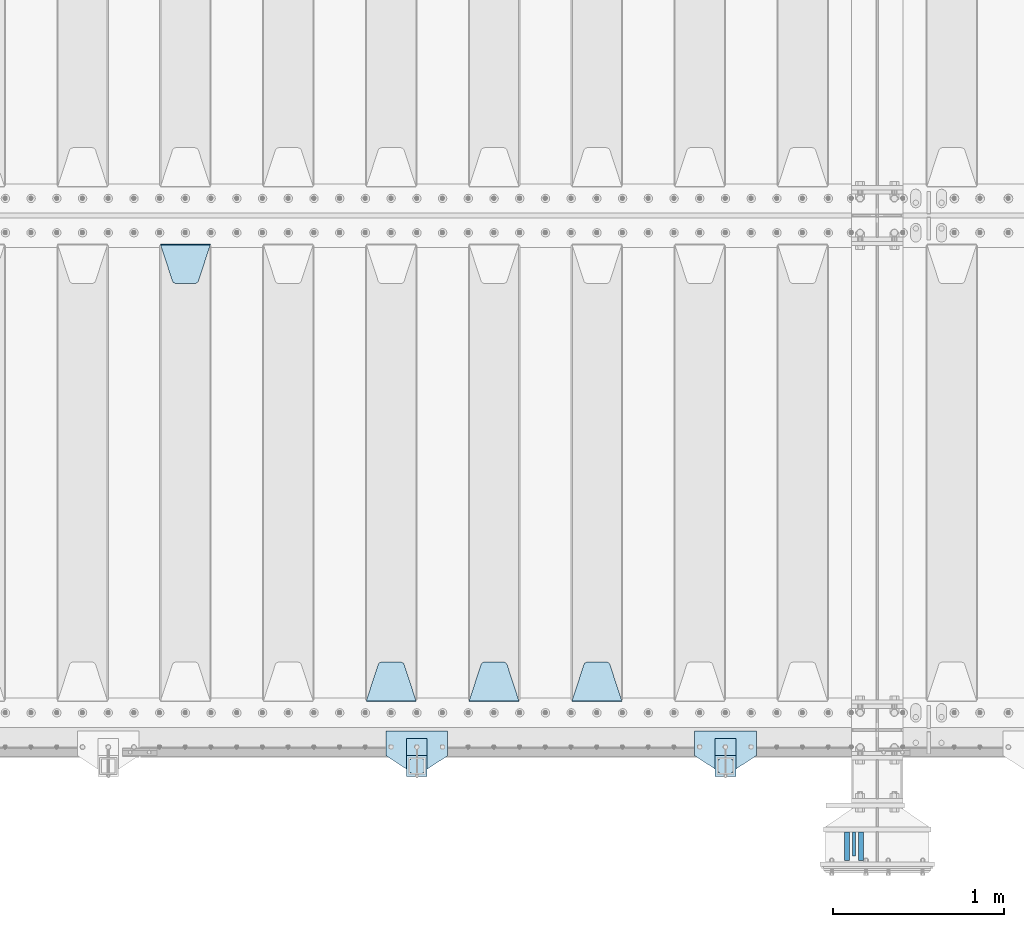
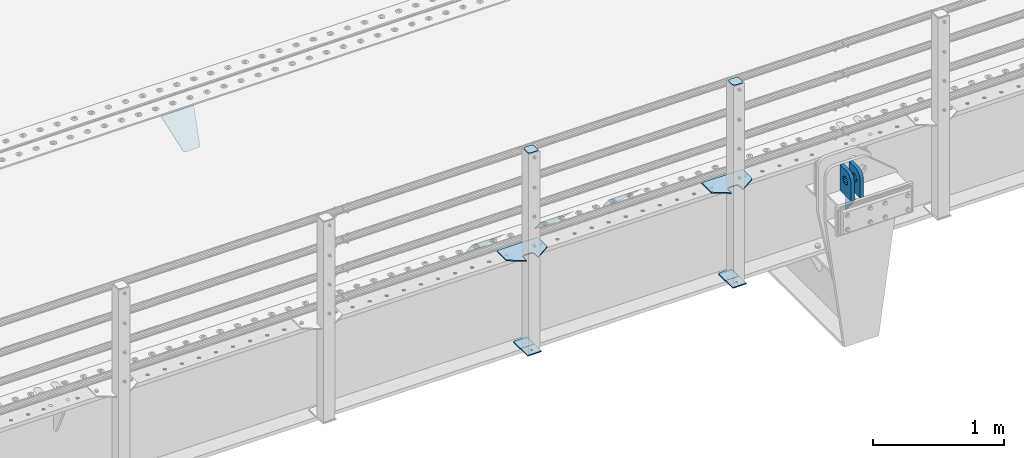
# One storey, part 222 of 270: 15 plates.
"""IFC2X3 building model written with IfcOpenShell, lengths in millimetres."""

from ifc_helpers import new_model, si_unit, frame, origin_with_axes, place, context, subcontext, project, spatial, faceted_brep, material, type_object, element, save


model = new_model("IFC2X3")

# Units and contexts
model_context = context("Model", 3, precision=1e-05, world=origin_with_axes())
body_context = subcontext(model_context, "Body", "Model", "MODEL_VIEW")
ifc_project = project(units=[si_unit("LENGTHUNIT", "METRE", prefix="MILLI"), si_unit("AREAUNIT", "SQUARE_METRE"), si_unit("VOLUMEUNIT", "CUBIC_METRE"), si_unit("MASSUNIT", "GRAM", prefix="KILO"), si_unit("TIMEUNIT", "SECOND"), si_unit("PLANEANGLEUNIT", "RADIAN"), si_unit("SOLIDANGLEUNIT", "STERADIAN"), si_unit("THERMODYNAMICTEMPERATUREUNIT", "DEGREE_CELSIUS"), si_unit("LUMINOUSINTENSITYUNIT", "LUMEN")], contexts=[model_context])

# Site, building, storey
site_placement = place(None, origin_with_axes())
site = spatial("IfcSite", under=ifc_project, at=site_placement, CompositionType="ELEMENT")
building_placement = place(site_placement, origin_with_axes())
building = spatial("IfcBuilding", under=site, at=building_placement, Name="Standard", CompositionType="ELEMENT")
storey_placement = place(building_placement, origin_with_axes())
storey = spatial("IfcBuildingStorey", under=building, at=storey_placement, Name="Undefined", CompositionType="ELEMENT", Elevation=0.0)

# Plates
ifc_material_1 = material(Name="STEEL/S355N")
plate_type_1 = type_object("IfcPlateType", PredefinedType="NOTDEFINED")
plate_1_placement = place(storey_placement, frame((13939.4999999902, -24594.9999999532, -10.0000182055919), z_axis=(0.0, -1.0, 0.0), x_axis=(0.0, 0.0, 1.0)))
element("IfcPlate", 1, at=plate_1_placement, inside=storey, type_object=plate_type_1, material=ifc_material_1, context=body_context, shape_type="Brep", body=[
    faceted_brep([(113.837049096098, 15.0, 53.837049096097), (113.837049096098, -15.0, 53.837049096097), (125.840713002492, -15.0, 45.8164572970818), (125.840713002492, 15.0, 45.8164572970818), (105.816457297082, 15.0, 65.8407130024916), (105.816457297082, -15.0, 65.8407130024916), (103.0, 15.0, 80.0), (103.0, -15.0, 80.0), (105.816457297082, 15.0, 94.1592869975084), (105.816457297082, -15.0, 94.1592869975084), (113.837049096098, 15.0, 106.162950903903), (113.837049096098, -15.0, 106.162950903903), (125.840713002492, 15.0, 114.183542702918), (125.840713002492, -15.0, 114.183542702918), (140.0, 15.0, 117.0), (140.0, -15.0, 117.0), (154.159286997508, 15.0, 114.183542702918), (154.159286997508, -15.0, 114.183542702918), (166.162950903902, 15.0, 106.162950903903), (166.162950903902, -15.0, 106.162950903903), (174.183542702918, 15.0, 94.1592869975084), (174.183542702918, -15.0, 94.1592869975084), (177.0, 15.0, 80.0), (177.0, -15.0, 80.0), (174.183542702918, 15.0, 65.8407130024916), (174.183542702918, -15.0, 65.8407130024916), (166.162950903902, 15.0, 53.837049096097), (166.162950903902, -15.0, 53.837049096097), (154.159286997508, 15.0, 45.8164572970818), (154.159286997508, -15.0, 45.8164572970818), (140.0, 15.0, 43.0), (140.0, -15.0, 43.0), (240.0, -15.0, 0.0), (240.001666876698, -15.0000000000018, 94.9959403776265), (237.616787699976, -15.0000000000018, 113.113322498939), (230.624045898169, -15.0000000000018, 129.996116868071), (219.499985670386, -15.0000000000018, 144.493787979867), (205.002693976271, -15.0000000000018, 155.618342674457), (188.120138118986, -15.0000000000018, 162.611660295071), (170.002837349484, -15.0000000000018, 164.997157401467), (0.0, -15.0, 165.0), (0.0, -15.0, 0.0), (0.0, 15.0, 0.0), (240.0, 15.0, 0.0), (240.001666876698, 14.9999999999982, 94.9959403776265), (237.616787699976, 14.9999999999982, 113.113322498935), (230.624045898169, 14.9999999999982, 129.996116868067), (219.499985670386, 14.9999999999982, 144.493787979864), (205.002693976271, 14.9999999999982, 155.618342674454), (188.120138118986, 14.9999999999982, 162.611660295068), (170.002837349484, 14.9999999999982, 164.997157401463), (0.0, 15.0, 165.0)], [[[0, 1, 2, 3]], [[4, 5, 1, 0]], [[6, 7, 5, 4]], [[8, 9, 7, 6]], [[10, 11, 9, 8]], [[12, 13, 11, 10]], [[14, 15, 13, 12]], [[16, 17, 15, 14]], [[18, 19, 17, 16]], [[20, 21, 19, 18]], [[22, 23, 21, 20]], [[24, 25, 23, 22]], [[26, 27, 25, 24]], [[28, 29, 27, 26]], [[30, 31, 29, 28]], [[3, 2, 31, 30]], [[32, 33, 34, 35, 36, 37, 38, 39, 40, 41], [19, 21, 23, 25, 27, 29, 31, 2, 1, 5, 7, 9, 11, 13, 15, 17]], [[32, 41, 42, 43]], [[33, 32, 43, 44]], [[34, 33, 44, 45]], [[35, 34, 45, 46]], [[36, 35, 46, 47]], [[37, 36, 47, 48]], [[38, 37, 48, 49]], [[39, 38, 49, 50]], [[40, 39, 50, 51]], [[41, 40, 51, 42]], [[50, 49, 48, 47, 46, 45, 44, 43, 42, 51], [10, 8, 6, 4, 0, 3, 30, 28, 26, 24, 22, 20, 18, 16, 14, 12]]]),
])
plate_2_placement = place(storey_placement, frame((13859.4999999919, -24594.9999999532, -10.0000182055919), z_axis=(0.0, -1.0, 0.0), x_axis=(0.0, 0.0, 1.0)))
element("IfcPlate", 2, at=plate_2_placement, inside=storey, type_object=plate_type_1, material=ifc_material_1, context=body_context, shape_type="Brep", body=[
    faceted_brep([(113.837049096098, 15.0, 53.837049096097), (113.837049096098, -15.0, 53.837049096097), (125.840713002492, -15.0, 45.8164572970818), (125.840713002492, 15.0, 45.8164572970818), (105.816457297082, 15.0, 65.8407130024916), (105.816457297082, -15.0, 65.8407130024916), (103.0, 15.0, 80.0), (103.0, -15.0, 80.0), (105.816457297082, 15.0, 94.1592869975084), (105.816457297082, -15.0, 94.1592869975084), (113.837049096098, 15.0, 106.162950903903), (113.837049096098, -15.0, 106.162950903903), (125.840713002492, 15.0, 114.183542702918), (125.840713002492, -15.0, 114.183542702918), (140.0, 15.0, 117.0), (140.0, -15.0, 117.0), (154.159286997508, 15.0, 114.183542702918), (154.159286997508, -15.0, 114.183542702918), (166.162950903902, 15.0, 106.162950903903), (166.162950903902, -15.0, 106.162950903903), (174.183542702918, 15.0, 94.1592869975084), (174.183542702918, -15.0, 94.1592869975084), (177.0, 15.0, 80.0), (177.0, -15.0, 80.0), (174.183542702918, 15.0, 65.8407130024916), (174.183542702918, -15.0, 65.8407130024916), (166.162950903902, 15.0, 53.837049096097), (166.162950903902, -15.0, 53.837049096097), (154.159286997508, 15.0, 45.8164572970818), (154.159286997508, -15.0, 45.8164572970818), (140.0, 15.0, 43.0), (140.0, -15.0, 43.0), (240.0, -15.0, 0.0), (240.0, -15.0, 95.0), (237.614807840235, -15.0, 113.117333157177), (230.621778264911, -15.0, 130.0), (219.497474683058, -15.0, 144.497474683058), (205.0, -15.0, 155.621778264911), (188.117333157176, -15.0, 162.614807840235), (170.0, -15.0, 165.0), (0.0, -15.0, 165.0), (0.0, -15.0, 0.0), (0.0, 15.0, 0.0), (240.0, 15.0, 0.0), (240.0, 15.0, 95.0), (237.614807840235, 15.0, 113.117333157177), (230.621778264911, 15.0, 130.0), (219.497474683058, 15.0, 144.497474683058), (205.0, 15.0, 155.621778264911), (188.117333157176, 15.0, 162.614807840235), (170.0, 15.0, 165.0), (0.0, 15.0, 165.0)], [[[0, 1, 2, 3]], [[4, 5, 1, 0]], [[6, 7, 5, 4]], [[8, 9, 7, 6]], [[10, 11, 9, 8]], [[12, 13, 11, 10]], [[14, 15, 13, 12]], [[16, 17, 15, 14]], [[18, 19, 17, 16]], [[20, 21, 19, 18]], [[22, 23, 21, 20]], [[24, 25, 23, 22]], [[26, 27, 25, 24]], [[28, 29, 27, 26]], [[30, 31, 29, 28]], [[3, 2, 31, 30]], [[32, 33, 34, 35, 36, 37, 38, 39, 40, 41], [19, 21, 23, 25, 27, 29, 31, 2, 1, 5, 7, 9, 11, 13, 15, 17]], [[32, 41, 42, 43]], [[33, 32, 43, 44]], [[34, 33, 44, 45]], [[35, 34, 45, 46]], [[36, 35, 46, 47]], [[37, 36, 47, 48]], [[38, 37, 48, 49]], [[39, 38, 49, 50]], [[40, 39, 50, 51]], [[41, 40, 51, 42]], [[50, 49, 48, 47, 46, 45, 44, 43, 42, 51], [10, 8, 6, 4, 0, 3, 30, 28, 26, 24, 22, 20, 18, 16, 14, 12]]]),
])
plate_type_2 = type_object("IfcPlateType", PredefinedType="NOTDEFINED")
plate_3_placement = place(storey_placement, frame((13899.4999999918, -24734.9999999532, -24.0000182055592), z_axis=(0.0, 0.0, -1.0), x_axis=(0.0, 1.0, 0.0)))
element("IfcPlate", 3, at=plate_3_placement, inside=storey, type_object=plate_type_2, material=ifc_material_1, context=body_context, shape_type="Brep", body=[
    faceted_brep([(0.0, -10.0, 0.0), (140.0, -10.0, 180.0), (140.0, 10.0, 180.0), (0.0, 10.0, 0.0), (140.0, -10.0, -1.81898940354586e-12), (140.0, 10.0, -1.81898940354586e-12)], [[[0, 1, 2, 3]], [[1, 4, 5, 2]], [[4, 0, 3, 5]], [[5, 3, 2]], [[4, 1, 0]]]),
])
ifc_material_2 = material(Name="STEEL/S355J2")
plate_type_3 = type_object("IfcPlateType", PredefinedType="NOTDEFINED")
plate_4_placement = place(storey_placement, frame((13330.0, -24005.0, 5.00000000004911), z_axis=(0.0, -1.0, 0.0), x_axis=(-1.0, 0.0, 0.0)))
element("IfcPlate", 4, at=plate_4_placement, inside=storey, type_object=plate_type_3, material=ifc_material_2, context=body_context, shape_type="Brep", body=[
    faceted_brep([(0.0, -5.0, 0.0), (2.31396552408114e-06, -5.0, 145.0), (2.31396552408114e-06, 5.0, 145.0), (0.0, 5.0, 0.0), (130.0, -5.0, 230.0), (130.0, 5.0, 230.0), (130.0, -5.0, 180.0), (130.0, 5.0, 180.0), (130.48036798992, -5.0, 175.122741949597), (130.48036798992, 5.0, 175.122741949597), (131.903011687216, -5.0, 170.432914190873), (131.903011687216, 5.0, 170.432914190873), (134.213259692435, -5.0, 166.11074417451), (134.213259692435, 5.0, 166.11074417451), (137.322330470335, -5.0, 162.322330470337), (137.322330470335, 5.0, 162.322330470337), (141.110744174512, -5.0, 159.213259692437), (141.110744174512, 5.0, 159.213259692437), (145.432914190871, -5.0, 156.903011687218), (145.432914190871, 5.0, 156.903011687218), (150.122741949595, -5.0, 155.48036798992), (150.122741949595, 5.0, 155.48036798992), (155.0, -5.0, 155.0), (155.0, 5.0, 155.0), (205.0, -5.0, 155.0), (205.0, 5.0, 155.0), (209.877258050405, -5.0, 155.48036798992), (209.877258050405, 5.0, 155.48036798992), (214.567085809129, -5.0, 156.903011687218), (214.567085809129, 5.0, 156.903011687218), (218.889255825488, -5.0, 159.213259692437), (218.889255825488, 5.0, 159.213259692437), (222.677669529665, -5.0, 162.322330470337), (222.677669529665, 5.0, 162.322330470337), (225.786740307565, -5.0, 166.11074417451), (225.786740307565, 5.0, 166.11074417451), (228.096988312784, -5.0, 170.432914190873), (228.096988312784, 5.0, 170.432914190873), (229.51963201008, -5.0, 175.122741949597), (229.51963201008, 5.0, 175.122741949597), (230.0, -5.0, 180.0), (230.0, 5.0, 180.0), (230.0, -5.0, 230.0), (230.0, 5.0, 230.0), (360.0, -5.0, 145.0), (360.0, 5.0, 145.0), (360.0, -5.0, -7.27595761418343e-12), (360.0, 5.0, -7.27595761418343e-12)], [[[0, 1, 2, 3]], [[1, 4, 5, 2]], [[4, 6, 7, 5]], [[6, 8, 9, 7]], [[8, 10, 11, 9]], [[10, 12, 13, 11]], [[12, 14, 15, 13]], [[14, 16, 17, 15]], [[16, 18, 19, 17]], [[18, 20, 21, 19]], [[20, 22, 23, 21]], [[22, 24, 25, 23]], [[24, 26, 27, 25]], [[26, 28, 29, 27]], [[28, 30, 31, 29]], [[30, 32, 33, 31]], [[32, 34, 35, 33]], [[34, 36, 37, 35]], [[36, 38, 39, 37]], [[38, 40, 41, 39]], [[40, 42, 43, 41]], [[42, 44, 45, 43]], [[44, 46, 47, 45]], [[46, 0, 3, 47]], [[5, 7, 9, 11, 13, 15, 17, 19, 21, 23, 25, 27, 29, 31, 33, 35, 37, 39, 41, 43, 45, 47, 3, 2]], [[46, 44, 42, 40, 38, 36, 34, 32, 30, 28, 26, 24, 22, 20, 18, 16, 14, 12, 10, 8, 6, 4, 1, 0]]]),
])
plate_5_placement = place(storey_placement, frame((11530.0, -24005.0, 5.00000000004911), z_axis=(0.0, -1.0, 0.0), x_axis=(-1.0, 0.0, 0.0)))
element("IfcPlate", 5, at=plate_5_placement, inside=storey, type_object=plate_type_3, material=ifc_material_2, context=body_context, shape_type="Brep", body=[
    faceted_brep([(0.0, -5.0, 0.0), (2.31396552408114e-06, -5.0, 145.0), (2.31396552408114e-06, 5.0, 145.0), (0.0, 5.0, 0.0), (130.0, -5.0, 230.0), (130.0, 5.0, 230.0), (130.0, -5.0, 180.0), (130.0, 5.0, 180.0), (130.48036798992, -5.0, 175.122741949597), (130.48036798992, 5.0, 175.122741949597), (131.903011687216, -5.0, 170.432914190873), (131.903011687216, 5.0, 170.432914190873), (134.213259692435, -5.0, 166.11074417451), (134.213259692435, 5.0, 166.11074417451), (137.322330470335, -5.0, 162.322330470337), (137.322330470335, 5.0, 162.322330470337), (141.110744174512, -5.0, 159.213259692437), (141.110744174512, 5.0, 159.213259692437), (145.432914190871, -5.0, 156.903011687218), (145.432914190871, 5.0, 156.903011687218), (150.122741949595, -5.0, 155.48036798992), (150.122741949595, 5.0, 155.48036798992), (155.0, -5.0, 155.0), (155.0, 5.0, 155.0), (205.0, -5.0, 155.0), (205.0, 5.0, 155.0), (209.877258050405, -5.0, 155.48036798992), (209.877258050405, 5.0, 155.48036798992), (214.567085809129, -5.0, 156.903011687218), (214.567085809129, 5.0, 156.903011687218), (218.889255825488, -5.0, 159.213259692437), (218.889255825488, 5.0, 159.213259692437), (222.677669529665, -5.0, 162.322330470337), (222.677669529665, 5.0, 162.322330470337), (225.786740307565, -5.0, 166.11074417451), (225.786740307565, 5.0, 166.11074417451), (228.096988312784, -5.0, 170.432914190873), (228.096988312784, 5.0, 170.432914190873), (229.51963201008, -5.0, 175.122741949597), (229.51963201008, 5.0, 175.122741949597), (230.0, -5.0, 180.0), (230.0, 5.0, 180.0), (230.0, -5.0, 230.0), (230.0, 5.0, 230.0), (360.0, -5.0, 145.0), (360.0, 5.0, 145.0), (360.0, -5.0, -7.27595761418343e-12), (360.0, 5.0, -7.27595761418343e-12)], [[[0, 1, 2, 3]], [[1, 4, 5, 2]], [[4, 6, 7, 5]], [[6, 8, 9, 7]], [[8, 10, 11, 9]], [[10, 12, 13, 11]], [[12, 14, 15, 13]], [[14, 16, 17, 15]], [[16, 18, 19, 17]], [[18, 20, 21, 19]], [[20, 22, 23, 21]], [[22, 24, 25, 23]], [[24, 26, 27, 25]], [[26, 28, 29, 27]], [[28, 30, 31, 29]], [[30, 32, 33, 31]], [[32, 34, 35, 33]], [[34, 36, 37, 35]], [[36, 38, 39, 37]], [[38, 40, 41, 39]], [[40, 42, 43, 41]], [[42, 44, 45, 43]], [[44, 46, 47, 45]], [[46, 0, 3, 47]], [[5, 7, 9, 11, 13, 15, 17, 19, 21, 23, 25, 27, 29, 31, 33, 35, 37, 39, 41, 43, 45, 47, 3, 2]], [[46, 44, 42, 40, 38, 36, 34, 32, 30, 28, 26, 24, 22, 20, 18, 16, 14, 12, 10, 8, 6, 4, 1, 0]]]),
])
plate_type_4 = type_object("IfcPlateType", PredefinedType="NOTDEFINED")
for number, where, z_axis, x_axis in (
    (6, (13209.9999999999, -24050.0000000002, -850.000000000002), (0.0, -1.0, 0.0), (-1.0, 0.0, 0.0)),
    (7, (11409.9999999999, -24050.0000000002, -850.000000000002), (0.0, -1.0, 0.0), (-1.0, 0.0, 0.0)),
):
    element("IfcPlate", number, at=place(storey_placement, frame(where, z_axis=z_axis, x_axis=x_axis)), inside=storey, type_object=plate_type_4, material=ifc_material_2, context=body_context, shape_type="Brep", body=[
        faceted_brep([(53.6360389691836, -5.0, 176.363961030471), (53.6360389691836, 5.0, 176.363961030471), (59.9999999998618, 5.0, 178.999999999793), (59.9999999998618, -5.0, 178.999999999793), (66.3639610305399, 5.0, 176.363961030471), (66.3639610305399, -5.0, 176.363961030471), (68.9999999998618, 5.0, 169.999999999793), (68.9999999998618, -5.0, 169.999999999793), (66.3639610305399, 5.0, 163.636038969114), (66.3639610305399, -5.0, 163.636038969114), (59.9999999998618, 5.0, 160.999999999793), (59.9999999998618, -5.0, 160.999999999793), (53.6360389691836, 5.0, 163.636038969114), (53.6360389691836, -5.0, 163.636038969114), (50.9999999998618, 5.0, 169.999999999793), (50.9999999998618, -5.0, 169.999999999793), (120.0, -5.0, 0.0), (120.0, -5.0, 220.0), (0.0, -5.0, 220.0), (0.0, -5.0, 0.0), (0.0, 5.0, 0.0), (120.0, 5.0, 0.0), (120.0, 5.0, 220.0), (0.0, 5.0, 220.0)], [[[0, 1, 2, 3]], [[3, 2, 4, 5]], [[5, 4, 6, 7]], [[7, 6, 8, 9]], [[9, 8, 10, 11]], [[11, 10, 12, 13]], [[13, 12, 14, 15]], [[15, 14, 1, 0]], [[16, 17, 18, 19], [11, 13, 15, 0, 3, 5, 7, 9]], [[16, 19, 20, 21]], [[17, 16, 21, 22]], [[18, 17, 22, 23]], [[19, 18, 23, 20]], [[22, 21, 20, 23], [2, 1, 14, 12, 10, 8, 6, 4]]]),
    ])
plate_type_5 = type_object("IfcPlateType", PredefinedType="NOTDEFINED")
plate_6_placement = place(storey_placement, frame((13105.9999999999, -24166.0000000002, 1012.50000000001), z_axis=(0.0, -1.0, 0.0), x_axis=(1.0, 0.0, 0.0)))
element("IfcPlate", 8, at=plate_6_placement, inside=storey, type_object=plate_type_5, material=ifc_material_2, context=body_context, shape_type="Brep", body=[
    faceted_brep([(0.0, -2.5, 19.0), (0.0, -2.5, 69.0), (0.0, 2.5, 69.0), (0.0, 2.5, 19.0), (0.476369668544066, -2.5, 73.2278977451697), (0.476369668544066, 2.5, 73.2278977451697), (1.88159150985302, -2.5, 77.2437910432327), (1.88159150985302, 2.5, 77.2437910432327), (4.14520183310742, -2.5, 80.8463062353167), (4.14520183310742, 2.5, 80.8463062353167), (7.15369376468516, -2.5, 83.8547981668926), (7.15369376468516, 2.5, 83.8547981668926), (10.7562089567655, -2.5, 86.1184084901452), (10.7562089567655, 2.5, 86.1184084901452), (14.7721022548285, -2.5, 87.5236303314541), (14.7721022548285, 2.5, 87.5236303314541), (19.0, -2.5, 88.0), (19.0, 2.5, 88.0), (69.0, -2.5, 88.0), (69.0, 2.5, 88.0), (73.2278977451715, -2.5, 87.5236303314541), (73.2278977451715, 2.5, 87.5236303314541), (77.2437910432345, -2.5, 86.1184084901452), (77.2437910432345, 2.5, 86.1184084901452), (80.8463062353148, -2.5, 83.8547981668926), (80.8463062353148, 2.5, 83.8547981668926), (83.8547981668926, -2.5, 80.8463062353167), (83.8547981668926, 2.5, 80.8463062353167), (86.118408490147, -2.5, 77.2437910432345), (86.118408490147, 2.5, 77.2437910432345), (87.5236303314559, -2.5, 73.2278977451697), (87.5236303314559, 2.5, 73.2278977451697), (88.0, -2.5, 69.0), (88.0, 2.5, 69.0), (88.0, -2.5, 19.0), (88.0, 2.5, 19.0), (87.5236303314559, -2.5, 14.7721022548303), (87.5236303314559, 2.5, 14.7721022548303), (86.118408490147, -2.5, 10.7562089567673), (86.118408490147, 2.5, 10.7562089567673), (83.8547981668926, -2.5, 7.15369376468334), (83.8547981668926, 2.5, 7.15369376468334), (80.8463062353148, -2.5, 4.14520183310742), (80.8463062353148, 2.5, 4.14520183310742), (77.2437910432345, -2.5, 1.88159150985484), (77.2437910432345, 2.5, 1.88159150985484), (73.2278977451715, -2.5, 0.476369668545885), (73.2278977451715, 2.5, 0.476369668545885), (69.0, -2.5, 0.0), (69.0, 2.5, 0.0), (19.0, -2.5, 0.0), (19.0, 2.5, 0.0), (14.7721022548285, -2.5, 0.476369668545885), (14.7721022548285, 2.5, 0.476369668545885), (10.7562089567655, -2.5, 1.88159150985484), (10.7562089567655, 2.5, 1.88159150985484), (7.15369376468516, -2.5, 4.14520183310742), (7.15369376468516, 2.5, 4.14520183310742), (4.14520183310742, -2.5, 7.15369376468334), (4.14520183310742, 2.5, 7.15369376468334), (1.88159150985302, -2.5, 10.7562089567673), (1.88159150985302, 2.5, 10.7562089567673), (0.476369668544066, -2.5, 14.7721022548303), (0.476369668544066, 2.5, 14.7721022548303)], [[[0, 1, 2, 3]], [[1, 4, 5, 2]], [[4, 6, 7, 5]], [[6, 8, 9, 7]], [[8, 10, 11, 9]], [[10, 12, 13, 11]], [[12, 14, 15, 13]], [[14, 16, 17, 15]], [[16, 18, 19, 17]], [[18, 20, 21, 19]], [[20, 22, 23, 21]], [[22, 24, 25, 23]], [[24, 26, 27, 25]], [[26, 28, 29, 27]], [[28, 30, 31, 29]], [[30, 32, 33, 31]], [[32, 34, 35, 33]], [[34, 36, 37, 35]], [[36, 38, 39, 37]], [[38, 40, 41, 39]], [[40, 42, 43, 41]], [[42, 44, 45, 43]], [[44, 46, 47, 45]], [[46, 48, 49, 47]], [[48, 50, 51, 49]], [[50, 52, 53, 51]], [[52, 54, 55, 53]], [[54, 56, 57, 55]], [[56, 58, 59, 57]], [[58, 60, 61, 59]], [[60, 62, 63, 61]], [[62, 0, 3, 63]], [[5, 7, 9, 11, 13, 15, 17, 19, 21, 23, 25, 27, 29, 31, 33, 35, 37, 39, 41, 43, 45, 47, 49, 51, 53, 55, 57, 59, 61, 63, 3, 2]], [[62, 60, 58, 56, 54, 52, 50, 48, 46, 44, 42, 40, 38, 36, 34, 32, 30, 28, 26, 24, 22, 20, 18, 16, 14, 12, 10, 8, 6, 4, 1, 0]]]),
])
plate_7_placement = place(storey_placement, frame((11305.9999999999, -24166.0000000002, 1012.50000000001), z_axis=(0.0, -1.0, 0.0), x_axis=(1.0, 0.0, 0.0)))
element("IfcPlate", 9, at=plate_7_placement, inside=storey, type_object=plate_type_5, material=ifc_material_2, context=body_context, shape_type="Brep", body=[
    faceted_brep([(0.0, -2.5, 19.0), (0.0, -2.5, 69.0), (0.0, 2.5, 69.0), (0.0, 2.5, 19.0), (0.476369668544066, -2.5, 73.2278977451697), (0.476369668544066, 2.5, 73.2278977451697), (1.88159150985302, -2.5, 77.2437910432327), (1.88159150985302, 2.5, 77.2437910432327), (4.14520183310742, -2.5, 80.8463062353167), (4.14520183310742, 2.5, 80.8463062353167), (7.15369376468516, -2.5, 83.8547981668926), (7.15369376468516, 2.5, 83.8547981668926), (10.7562089567655, -2.5, 86.1184084901452), (10.7562089567655, 2.5, 86.1184084901452), (14.7721022548285, -2.5, 87.5236303314541), (14.7721022548285, 2.5, 87.5236303314541), (19.0, -2.5, 88.0), (19.0, 2.5, 88.0), (69.0, -2.5, 88.0), (69.0, 2.5, 88.0), (73.2278977451715, -2.5, 87.5236303314541), (73.2278977451715, 2.5, 87.5236303314541), (77.2437910432345, -2.5, 86.1184084901452), (77.2437910432345, 2.5, 86.1184084901452), (80.8463062353148, -2.5, 83.8547981668926), (80.8463062353148, 2.5, 83.8547981668926), (83.8547981668926, -2.5, 80.8463062353167), (83.8547981668926, 2.5, 80.8463062353167), (86.118408490147, -2.5, 77.2437910432345), (86.118408490147, 2.5, 77.2437910432345), (87.5236303314559, -2.5, 73.2278977451697), (87.5236303314559, 2.5, 73.2278977451697), (88.0, -2.5, 69.0), (88.0, 2.5, 69.0), (88.0, -2.5, 19.0), (88.0, 2.5, 19.0), (87.5236303314559, -2.5, 14.7721022548303), (87.5236303314559, 2.5, 14.7721022548303), (86.118408490147, -2.5, 10.7562089567673), (86.118408490147, 2.5, 10.7562089567673), (83.8547981668926, -2.5, 7.15369376468334), (83.8547981668926, 2.5, 7.15369376468334), (80.8463062353148, -2.5, 4.14520183310742), (80.8463062353148, 2.5, 4.14520183310742), (77.2437910432345, -2.5, 1.88159150985484), (77.2437910432345, 2.5, 1.88159150985484), (73.2278977451715, -2.5, 0.476369668545885), (73.2278977451715, 2.5, 0.476369668545885), (69.0, -2.5, 0.0), (69.0, 2.5, 0.0), (19.0, -2.5, 0.0), (19.0, 2.5, 0.0), (14.7721022548285, -2.5, 0.476369668545885), (14.7721022548285, 2.5, 0.476369668545885), (10.7562089567655, -2.5, 1.88159150985484), (10.7562089567655, 2.5, 1.88159150985484), (7.15369376468516, -2.5, 4.14520183310742), (7.15369376468516, 2.5, 4.14520183310742), (4.14520183310742, -2.5, 7.15369376468334), (4.14520183310742, 2.5, 7.15369376468334), (1.88159150985302, -2.5, 10.7562089567673), (1.88159150985302, 2.5, 10.7562089567673), (0.476369668544066, -2.5, 14.7721022548303), (0.476369668544066, 2.5, 14.7721022548303)], [[[0, 1, 2, 3]], [[1, 4, 5, 2]], [[4, 6, 7, 5]], [[6, 8, 9, 7]], [[8, 10, 11, 9]], [[10, 12, 13, 11]], [[12, 14, 15, 13]], [[14, 16, 17, 15]], [[16, 18, 19, 17]], [[18, 20, 21, 19]], [[20, 22, 23, 21]], [[22, 24, 25, 23]], [[24, 26, 27, 25]], [[26, 28, 29, 27]], [[28, 30, 31, 29]], [[30, 32, 33, 31]], [[32, 34, 35, 33]], [[34, 36, 37, 35]], [[36, 38, 39, 37]], [[38, 40, 41, 39]], [[40, 42, 43, 41]], [[42, 44, 45, 43]], [[44, 46, 47, 45]], [[46, 48, 49, 47]], [[48, 50, 51, 49]], [[50, 52, 53, 51]], [[52, 54, 55, 53]], [[54, 56, 57, 55]], [[56, 58, 59, 57]], [[58, 60, 61, 59]], [[60, 62, 63, 61]], [[62, 0, 3, 63]], [[5, 7, 9, 11, 13, 15, 17, 19, 21, 23, 25, 27, 29, 31, 33, 35, 37, 39, 41, 43, 45, 47, 49, 51, 53, 55, 57, 59, 61, 63, 3, 2]], [[62, 60, 58, 56, 54, 52, 50, 48, 46, 44, 42, 40, 38, 36, 34, 32, 30, 28, 26, 24, 22, 20, 18, 16, 14, 12, 10, 8, 6, 4, 1, 0]]]),
])
plate_type_6 = type_object("IfcPlateType", PredefinedType="NOTDEFINED")
for number, where, z_axis, x_axis in (
    (10, (13209.9999999999, -24050.0000000002, -857.500000000002), (0.0, -1.0, 0.0), (-1.0, 0.0, 0.0)),
    (11, (11409.9999999999, -24050.0000000002, -857.500000000002), (0.0, -1.0, 0.0), (-1.0, 0.0, 0.0)),
):
    element("IfcPlate", number, at=place(storey_placement, frame(where, z_axis=z_axis, x_axis=x_axis)), inside=storey, type_object=plate_type_6, material=ifc_material_2, context=body_context, shape_type="Brep", body=[
        faceted_brep([(0.0, -2.5, 0.0), (0.0, -2.5, 100.0), (0.0, 2.5, 100.0), (0.0, 2.5, 0.0), (120.0, -2.5, 100.0), (120.0, 2.5, 100.0), (120.0, -2.5, 0.0), (120.0, 2.5, 0.0)], [[[0, 1, 2, 3]], [[1, 4, 5, 2]], [[4, 6, 7, 5]], [[6, 0, 3, 7]], [[5, 7, 3, 2]], [[6, 4, 1, 0]]]),
    ])
plate_type_7 = type_object("IfcPlateType", PredefinedType="NOTDEFINED")
plate_8_placement = place(storey_placement, frame((12545.0, -23831.767766953, -1.76776695296758), z_axis=(0.0, 0.707106781186547, -0.707106781186548), x_axis=(-1.0, 0.0, 0.0)))
element("IfcPlate", 12, at=plate_8_placement, inside=storey, type_object=plate_type_7, material=ifc_material_1, context=body_context, shape_type="Brep", body=[
    faceted_brep([(0.0, -2.5, 0.0), (69.345504679477, -2.5, 300.171731424831), (69.345504679477, 2.5, 300.171731424831), (0.0, 2.5, 0.0), (70.9274061199576, -2.5, 304.8974424154), (70.9274061199576, 2.5, 304.8974424154), (73.3818627772307, -2.49999999999818, 309.234538108527), (73.3818627772307, 2.50000000000182, 309.234538108527), (76.6187032999551, -2.5, 313.023683126103), (76.6187032999551, 2.5, 313.023683126103), (80.5190132704993, -2.5, 316.125672595372), (80.5190132704993, 2.50000000000182, 316.125672595372), (84.9395038596849, -2.49999999999818, 318.426546230476), (84.9395038596849, 2.5, 318.426546230476), (89.7177759439219, -2.49999999999818, 319.841774983275), (89.7177759439219, 2.50000000000182, 319.841774983275), (94.678286292652, -2.5, 320.319366455078), (94.678286292652, 2.5, 320.319366455078), (195.321713707348, -2.5, 320.319366455078), (195.321713707348, 2.5, 320.319366455078), (200.282224056078, -2.49999999999818, 319.841774983275), (200.282224056078, 2.50000000000182, 319.841774983275), (205.060496140315, -2.5, 318.426546230476), (205.060496140315, 2.5, 318.426546230476), (209.480986729501, -2.5, 316.12567259537), (209.480986729501, 2.50000000000182, 316.12567259537), (213.381296700045, -2.5, 313.023683126103), (213.381296700045, 2.5, 313.023683126103), (216.618137222769, -2.49999999999818, 309.234538108525), (216.618137222769, 2.50000000000182, 309.234538108527), (219.072593880042, -2.49999999999818, 304.897442415398), (219.072593880042, 2.50000000000182, 304.897442415397), (220.654495320523, -2.5, 300.171731424831), (220.654495320523, 2.5, 300.171731424831), (290.0, -2.49999999999818, 0.0), (290.0, 2.5, 0.0)], [[[0, 1, 2, 3]], [[1, 4, 5, 2]], [[4, 6, 7, 5]], [[6, 8, 9, 7]], [[8, 10, 11, 9]], [[10, 12, 13, 11]], [[12, 14, 15, 13]], [[14, 16, 17, 15]], [[16, 18, 19, 17]], [[18, 20, 21, 19]], [[20, 22, 23, 21]], [[22, 24, 25, 23]], [[24, 26, 27, 25]], [[26, 28, 29, 27]], [[28, 30, 31, 29]], [[30, 32, 33, 31]], [[32, 34, 35, 33]], [[34, 0, 3, 35]], [[5, 7, 9, 11, 13, 15, 17, 19, 21, 23, 25, 27, 29, 31, 33, 35, 3, 2]], [[34, 32, 30, 28, 26, 24, 22, 20, 18, 16, 14, 12, 10, 8, 6, 4, 1, 0]]]),
])
plate_9_placement = place(storey_placement, frame((11945.0, -23831.767766953, -1.76776695296758), z_axis=(0.0, 0.707106781186547, -0.707106781186548), x_axis=(-1.0, 0.0, 0.0)))
element("IfcPlate", 13, at=plate_9_placement, inside=storey, type_object=plate_type_7, material=ifc_material_1, context=body_context, shape_type="Brep", body=[
    faceted_brep([(0.0, -2.5, 0.0), (69.345504679477, -2.5, 300.171731424831), (69.345504679477, 2.5, 300.171731424831), (0.0, 2.5, 0.0), (70.9274061199576, -2.5, 304.8974424154), (70.9274061199576, 2.5, 304.8974424154), (73.3818627772307, -2.49999999999818, 309.234538108527), (73.3818627772307, 2.50000000000182, 309.234538108527), (76.6187032999551, -2.5, 313.023683126103), (76.6187032999551, 2.5, 313.023683126103), (80.5190132704993, -2.5, 316.125672595372), (80.5190132704993, 2.50000000000182, 316.125672595372), (84.9395038596849, -2.49999999999818, 318.426546230476), (84.9395038596849, 2.5, 318.426546230476), (89.7177759439219, -2.49999999999818, 319.841774983275), (89.7177759439219, 2.50000000000182, 319.841774983275), (94.678286292652, -2.5, 320.319366455078), (94.678286292652, 2.5, 320.319366455078), (195.321713707348, -2.5, 320.319366455078), (195.321713707348, 2.5, 320.319366455078), (200.282224056078, -2.49999999999818, 319.841774983275), (200.282224056078, 2.50000000000182, 319.841774983275), (205.060496140315, -2.5, 318.426546230476), (205.060496140315, 2.5, 318.426546230476), (209.480986729501, -2.5, 316.12567259537), (209.480986729501, 2.50000000000182, 316.12567259537), (213.381296700045, -2.5, 313.023683126103), (213.381296700045, 2.5, 313.023683126103), (216.618137222769, -2.49999999999818, 309.234538108525), (216.618137222769, 2.50000000000182, 309.234538108527), (219.072593880042, -2.49999999999818, 304.897442415398), (219.072593880042, 2.50000000000182, 304.897442415397), (220.654495320523, -2.5, 300.171731424831), (220.654495320523, 2.5, 300.171731424831), (290.0, -2.49999999999818, 0.0), (290.0, 2.5, 0.0)], [[[0, 1, 2, 3]], [[1, 4, 5, 2]], [[4, 6, 7, 5]], [[6, 8, 9, 7]], [[8, 10, 11, 9]], [[10, 12, 13, 11]], [[12, 14, 15, 13]], [[14, 16, 17, 15]], [[16, 18, 19, 17]], [[18, 20, 21, 19]], [[20, 22, 23, 21]], [[22, 24, 25, 23]], [[24, 26, 27, 25]], [[26, 28, 29, 27]], [[28, 30, 31, 29]], [[30, 32, 33, 31]], [[32, 34, 35, 33]], [[34, 0, 3, 35]], [[5, 7, 9, 11, 13, 15, 17, 19, 21, 23, 25, 27, 29, 31, 33, 35, 3, 2]], [[34, 32, 30, 28, 26, 24, 22, 20, 18, 16, 14, 12, 10, 8, 6, 4, 1, 0]]]),
])
plate_10_placement = place(storey_placement, frame((11345.0, -23831.767766953, -1.76776695296758), z_axis=(0.0, 0.707106781186547, -0.707106781186548), x_axis=(-1.0, 0.0, 0.0)))
element("IfcPlate", 14, at=plate_10_placement, inside=storey, type_object=plate_type_7, material=ifc_material_1, context=body_context, shape_type="Brep", body=[
    faceted_brep([(0.0, -2.5, 0.0), (69.345504679477, -2.5, 300.171731424831), (69.345504679477, 2.5, 300.171731424831), (0.0, 2.5, 0.0), (70.9274061199576, -2.5, 304.8974424154), (70.9274061199576, 2.5, 304.8974424154), (73.3818627772307, -2.49999999999818, 309.234538108527), (73.3818627772307, 2.50000000000182, 309.234538108527), (76.6187032999551, -2.5, 313.023683126103), (76.6187032999551, 2.5, 313.023683126103), (80.5190132704993, -2.5, 316.125672595372), (80.5190132704993, 2.50000000000182, 316.125672595372), (84.9395038596849, -2.49999999999818, 318.426546230476), (84.9395038596849, 2.5, 318.426546230476), (89.7177759439219, -2.49999999999818, 319.841774983275), (89.7177759439219, 2.50000000000182, 319.841774983275), (94.678286292652, -2.5, 320.319366455078), (94.678286292652, 2.5, 320.319366455078), (195.321713707348, -2.5, 320.319366455078), (195.321713707348, 2.5, 320.319366455078), (200.282224056078, -2.49999999999818, 319.841774983275), (200.282224056078, 2.50000000000182, 319.841774983275), (205.060496140315, -2.5, 318.426546230476), (205.060496140315, 2.5, 318.426546230476), (209.480986729501, -2.5, 316.12567259537), (209.480986729501, 2.50000000000182, 316.12567259537), (213.381296700045, -2.5, 313.023683126103), (213.381296700045, 2.5, 313.023683126103), (216.618137222769, -2.49999999999818, 309.234538108525), (216.618137222769, 2.50000000000182, 309.234538108527), (219.072593880042, -2.49999999999818, 304.897442415398), (219.072593880042, 2.50000000000182, 304.897442415397), (220.654495320523, -2.5, 300.171731424831), (220.654495320523, 2.5, 300.171731424831), (290.0, -2.49999999999818, 0.0), (290.0, 2.5, 0.0)], [[[0, 1, 2, 3]], [[1, 4, 5, 2]], [[4, 6, 7, 5]], [[6, 8, 9, 7]], [[8, 10, 11, 9]], [[10, 12, 13, 11]], [[12, 14, 15, 13]], [[14, 16, 17, 15]], [[16, 18, 19, 17]], [[18, 20, 21, 19]], [[20, 22, 23, 21]], [[22, 24, 25, 23]], [[24, 26, 27, 25]], [[26, 28, 29, 27]], [[28, 30, 31, 29]], [[30, 32, 33, 31]], [[32, 34, 35, 33]], [[34, 0, 3, 35]], [[5, 7, 9, 11, 13, 15, 17, 19, 21, 23, 25, 27, 29, 31, 33, 35, 3, 2]], [[34, 32, 30, 28, 26, 24, 22, 20, 18, 16, 14, 12, 10, 8, 6, 4, 1, 0]]]),
])
plate_11_placement = place(storey_placement, frame((9855.0, -21168.232233044, -1.76776695296576), z_axis=(0.0, -0.707106781186548, -0.707106781186547), x_axis=(1.0, 0.0, 0.0)))
element("IfcPlate", 15, at=plate_11_placement, inside=storey, type_object=plate_type_7, material=ifc_material_1, context=body_context, shape_type="Brep", body=[
    faceted_brep([(0.0, -2.5, 0.0), (69.345504679477, -2.5, 300.171731424831), (69.345504679477, 2.5, 300.171731424831), (0.0, 2.5, 0.0), (70.9274061199576, -2.5, 304.8974424154), (70.9274061199576, 2.5, 304.8974424154), (73.3818627772307, -2.49999999999818, 309.234538108527), (73.3818627772307, 2.50000000000182, 309.234538108527), (76.6187032999551, -2.5, 313.023683126103), (76.6187032999551, 2.5, 313.023683126103), (80.5190132704993, -2.5, 316.125672595372), (80.5190132704993, 2.50000000000182, 316.125672595372), (84.9395038596849, -2.49999999999818, 318.426546230476), (84.9395038596849, 2.5, 318.426546230476), (89.7177759439219, -2.49999999999818, 319.841774983275), (89.7177759439219, 2.50000000000182, 319.841774983275), (94.678286292652, -2.5, 320.319366455078), (94.678286292652, 2.5, 320.319366455078), (195.321713707348, -2.5, 320.319366455078), (195.321713707348, 2.5, 320.319366455078), (200.282224056078, -2.49999999999818, 319.841774983275), (200.282224056078, 2.50000000000182, 319.841774983275), (205.060496140315, -2.5, 318.426546230476), (205.060496140315, 2.5, 318.426546230476), (209.480986729501, -2.5, 316.12567259537), (209.480986729501, 2.50000000000182, 316.12567259537), (213.381296700045, -2.5, 313.023683126103), (213.381296700045, 2.5, 313.023683126103), (216.618137222769, -2.49999999999818, 309.234538108525), (216.618137222769, 2.50000000000182, 309.234538108527), (219.072593880042, -2.49999999999818, 304.897442415398), (219.072593880042, 2.50000000000182, 304.897442415397), (220.654495320523, -2.5, 300.171731424831), (220.654495320523, 2.5, 300.171731424831), (290.0, -2.49999999999818, 0.0), (290.0, 2.5, 0.0)], [[[0, 1, 2, 3]], [[1, 4, 5, 2]], [[4, 6, 7, 5]], [[6, 8, 9, 7]], [[8, 10, 11, 9]], [[10, 12, 13, 11]], [[12, 14, 15, 13]], [[14, 16, 17, 15]], [[16, 18, 19, 17]], [[18, 20, 21, 19]], [[20, 22, 23, 21]], [[22, 24, 25, 23]], [[24, 26, 27, 25]], [[26, 28, 29, 27]], [[28, 30, 31, 29]], [[30, 32, 33, 31]], [[32, 34, 35, 33]], [[34, 0, 3, 35]], [[5, 7, 9, 11, 13, 15, 17, 19, 21, 23, 25, 27, 29, 31, 33, 35, 3, 2]], [[34, 32, 30, 28, 26, 24, 22, 20, 18, 16, 14, 12, 10, 8, 6, 4, 1, 0]]]),
])

save(model, "model.ifc")
